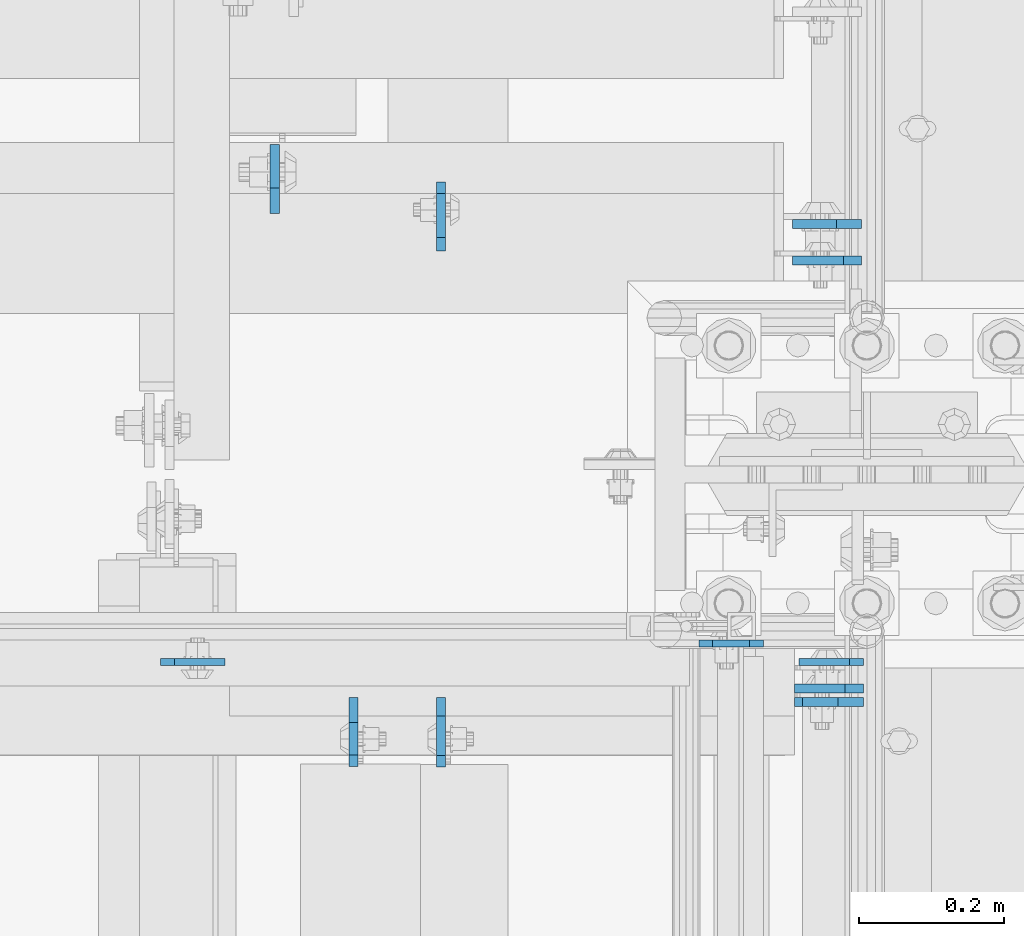
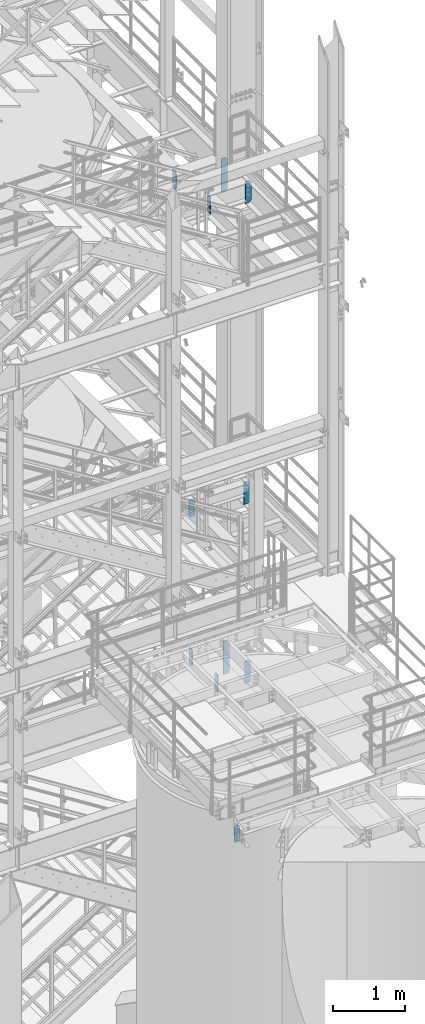
# One storey, part 1504 of 1876: 11 plates, 11 elements without a shape of their own.
"""IFC2X3 building model written with IfcOpenShell, lengths in millimetres."""

from ifc_helpers import new_model, si_unit, frame, origin_with_axes, place, context, subcontext, project, spatial, faceted_brep, material, type_object, element, aggregate, save


model = new_model("IFC2X3")

# Units and contexts
model_context = context("Model", 3, precision=1e-05, world=origin_with_axes())
body_context = subcontext(model_context, "Body", "Model", "MODEL_VIEW")
ifc_project = project(units=[si_unit("LENGTHUNIT", "METRE", prefix="MILLI"), si_unit("AREAUNIT", "SQUARE_METRE"), si_unit("VOLUMEUNIT", "CUBIC_METRE"), si_unit("MASSUNIT", "GRAM", prefix="KILO"), si_unit("TIMEUNIT", "SECOND"), si_unit("PLANEANGLEUNIT", "RADIAN"), si_unit("SOLIDANGLEUNIT", "STERADIAN"), si_unit("THERMODYNAMICTEMPERATUREUNIT", "DEGREE_CELSIUS"), si_unit("LUMINOUSINTENSITYUNIT", "LUMEN")], contexts=[model_context])

# Site, building, storey
site_placement = place(None, origin_with_axes())
site = spatial("IfcSite", under=ifc_project, at=site_placement, CompositionType="ELEMENT")
building_placement = place(site_placement, origin_with_axes())
building = spatial("IfcBuilding", under=site, at=building_placement, Name="Undefined", CompositionType="ELEMENT")
storey_placement = place(building_placement, origin_with_axes())
storey = spatial("IfcBuildingStorey", under=building, at=storey_placement, Name="Undefined", CompositionType="ELEMENT", Elevation=0.0)

# Assembly, plate
assembly_1_placement = place(storey_placement, origin_with_axes())
assembly_1 = element("IfcElementAssembly", 1, at=assembly_1_placement, inside=storey, Name="STRINGER", AssemblyPlace="NOTDEFINED", PredefinedType="RIGID_FRAME")
ifc_material = material(Name="STEEL/A36")
plate_type_1 = type_object("IfcPlateType", PredefinedType="NOTDEFINED")
plate_1_placement = place(assembly_1_placement, frame((7477.125, -4805.36300113047, 2044.9625725), z_axis=(-0.164335003932498, 0.0, 0.986404585594829), x_axis=(-0.986404585594829, 0.0, -0.164335003932498)))
plate_1 = element("IfcPlate", 2, at=plate_1_placement, type_object=plate_type_1, material=ifc_material, Name="PLATE", context=body_context, shape_type="Brep", body=[
    faceted_brep([(-3.13058175286437, -4.76249999999982, 18.7910065941451), (-40.8721457557156, -4.76249999999982, 245.331002683401), (-40.8721457557156, 4.76249999999982, 245.331002683401), (-3.13058175286437, 4.76249999999982, 18.7910065941451), (-25.9816576370417, -4.76249999999982, 270.29805264019), (-25.9816576370417, 4.76249999999982, 270.29805264019), (23.2336489088775, -4.76249999999982, 287.164746432251), (23.2336489088775, 4.76249999999982, 287.164746432251), (44.3853002035203, -4.76249999999982, 274.549783145812), (44.3853002035203, 4.76249999999982, 274.549783145812), (86.9947084938813, -4.76249999999982, 18.7910066490629), (86.9947084938813, 4.76249999999982, 18.7910066490629), (71.075290679928, -4.76249999999982, -2.95585778076202e-12), (71.075290679928, 4.76249999999982, -2.95585778076202e-12), (19.0499992370605, -4.76249999999982, 0.0), (19.0499992370605, 4.76249999999982, 0.0)], [[[0, 1, 2, 3]], [[1, 4, 5, 2]], [[4, 6, 7, 5]], [[6, 8, 9, 7]], [[8, 10, 11, 9]], [[10, 12, 13, 11]], [[12, 14, 15, 13]], [[14, 0, 3, 15]], [[5, 7, 9, 11, 13, 15, 3, 2]], [[14, 12, 10, 8, 6, 4, 1, 0]]]),
])
aggregate(assembly_1, [plate_1])

assembly_2_placement = place(storey_placement, origin_with_axes())
assembly_2 = element("IfcElementAssembly", 3, at=assembly_2_placement, inside=storey, Name="BEAM", AssemblyPlace="NOTDEFINED", PredefinedType="RIGID_FRAME")
plate_2_placement = place(assembly_2_placement, frame((7615.2375, -4830.76200121504, 7759.7), z_axis=(0.0, 0.0, 1.0), x_axis=(-1.0, 0.0, 0.0)))
plate_2 = element("IfcPlate", 4, at=plate_2_placement, type_object=plate_type_1, material=ifc_material, Name="PLATE", context=body_context, shape_type="Brep", body=[
    faceted_brep([(0.0, -4.76249999999982, 19.0499992370605), (0.0, -4.76250000000005, 360.362506866455), (0.0, 4.76250000000005, 360.362506866455), (0.0, 4.76249999999982, 19.0499992370605), (19.0499992370605, -4.76250000000005, 379.412506103516), (19.0499992370605, 4.76250000000005, 379.412506103516), (88.9000015258789, -4.76250000000005, 379.412506103516), (88.9000015258789, 4.76250000000005, 379.412506103516), (88.9000015258789, -4.76249999999982, 0.0), (88.9000015258789, 4.76249999999982, 0.0), (19.0499992370605, -4.76249999999982, 0.0), (19.0499992370605, 4.76249999999982, 0.0)], [[[0, 1, 2, 3]], [[1, 4, 5, 2]], [[4, 6, 7, 5]], [[6, 8, 9, 7]], [[8, 10, 11, 9]], [[10, 0, 3, 11]], [[5, 7, 9, 11, 3, 2]], [[10, 8, 6, 4, 1, 0]]]),
])
aggregate(assembly_2, [plate_2])

assembly_3_placement = place(storey_placement, origin_with_axes())
assembly_3 = element("IfcElementAssembly", 5, at=assembly_3_placement, inside=storey, Name="BEAM", AssemblyPlace="NOTDEFINED", PredefinedType="RIGID_FRAME")
plate_3_placement = place(assembly_3_placement, frame((6645.671875, -4830.76200121504, 7851.775), z_axis=(0.0, 0.0, 1.0), x_axis=(1.0, 0.0, 0.0)))
plate_3 = element("IfcPlate", 6, at=plate_3_placement, type_object=plate_type_1, material=ifc_material, Name="PLATE", context=body_context, shape_type="Brep", body=[
    faceted_brep([(0.0, -4.76249999999982, 19.0499992370605), (0.0, -4.76249999999982, 271.462512969971), (0.0, 4.76249999999982, 271.462512969971), (0.0, 4.76249999999982, 19.0499992370605), (19.0499992370605, -4.76249999999982, 290.512512207031), (19.0499992370605, 4.76249999999982, 290.512512207031), (88.9000015258789, -4.76249999999982, 290.512512207031), (88.9000015258789, 4.76249999999982, 290.512512207031), (88.9000015258789, -4.76249999999982, 0.0), (88.9000015258789, 4.76249999999982, 0.0), (19.0499992370605, -4.76249999999982, 0.0), (19.0499992370605, 4.76249999999982, 0.0)], [[[0, 1, 2, 3]], [[1, 4, 5, 2]], [[4, 6, 7, 5]], [[6, 8, 9, 7]], [[8, 10, 11, 9]], [[10, 0, 3, 11]], [[5, 7, 9, 11, 3, 2]], [[10, 8, 6, 4, 1, 0]]]),
])
aggregate(assembly_3, [plate_3])

assembly_4_placement = place(storey_placement, origin_with_axes())
assembly_4 = element("IfcElementAssembly", 7, at=assembly_4_placement, inside=storey, Name="BEAM", AssemblyPlace="NOTDEFINED", PredefinedType="RIGID_FRAME")
plate_type_2 = type_object("IfcPlateType", PredefinedType="NOTDEFINED")
plate_4_placement = place(assembly_4_placement, frame((6911.97499990463, -4879.578125, 13007.975), z_axis=(0.0, 0.0, 1.0), x_axis=(0.0, -1.0, 0.0)))
plate_4 = element("IfcPlate", 8, at=plate_4_placement, type_object=plate_type_2, material=ifc_material, Name="PLATE", context=body_context, shape_type="Brep", body=[
    faceted_brep([(0.0, -6.35000000000036, 255.587512969971), (34.9249992370605, -6.35000000000036, 290.512512207031), (34.9249992370605, 6.35000000000036, 290.512512207031), (0.0, 6.35000000000036, 255.587512969971), (0.0, -6.34999999999991, 34.9249992370605), (0.0, 6.34999999999991, 34.9249992370605), (34.9249992370605, -6.34999999999991, 0.0), (34.9249992370605, 6.34999999999991, 0.0), (95.25, -6.35000000000036, 0.0), (95.25, 6.35000000000036, 0.0), (95.25, -6.35000000000036, 277.812512016344), (79.3749874887271, -6.35000000000036, 290.512512207031), (79.3749874887271, 6.35000000000036, 290.512512207031), (95.25, 6.35000000000036, 277.812512016344)], [[[0, 1, 2, 3]], [[4, 0, 3, 5]], [[6, 4, 5, 7]], [[8, 6, 7, 9]], [[1, 0, 4, 6, 8, 10, 11]], [[2, 1, 11, 12]], [[9, 7, 5, 3, 2, 12, 13]], [[8, 9, 13, 10]], [[12, 11, 10, 13]]]),
])
aggregate(assembly_4, [plate_4])

assembly_5_placement = place(storey_placement, origin_with_axes())
assembly_5 = element("IfcElementAssembly", 9, at=assembly_5_placement, inside=storey, Name="BEAM", AssemblyPlace="NOTDEFINED", PredefinedType="RIGID_FRAME")
plate_5_placement = place(assembly_5_placement, frame((7615.2375, -4885.92812509537, 12915.9), z_axis=(0.0, 0.0, 1.0), x_axis=(-1.0, 0.0, 0.0)))
plate_5 = element("IfcPlate", 10, at=plate_5_placement, type_object=plate_type_2, material=ifc_material, Name="PLATE", context=body_context, shape_type="Brep", body=[
    faceted_brep([(0.0, -6.35000000000036, 344.487506866455), (34.9249992370605, -6.35000000000036, 379.412506103516), (34.9249992370605, 6.35000000000036, 379.412506103516), (0.0, 6.35000000000036, 344.487506866455), (0.0, -6.34999999999991, 34.9249992370605), (0.0, 6.34999999999991, 34.9249992370605), (34.9249992370605, -6.34999999999991, 0.0), (34.9249992370605, 6.34999999999991, 0.0), (95.25, -6.35000000000036, 0.0), (95.25, 6.35000000000036, 0.0), (95.25, -6.35000000000036, 368.300005476489), (84.136993261126, -6.35000000000036, 379.412506103516), (84.136993261126, 6.35000000000036, 379.412506103516), (95.25, 6.35000000000036, 368.300005476489)], [[[0, 1, 2, 3]], [[4, 0, 3, 5]], [[6, 4, 5, 7]], [[8, 6, 7, 9]], [[1, 0, 4, 6, 8, 10, 11]], [[2, 1, 11, 12]], [[9, 7, 5, 3, 2, 12, 13]], [[8, 9, 13, 10]], [[12, 11, 10, 13]]]),
])
aggregate(assembly_5, [plate_5])

assembly_6_placement = place(storey_placement, origin_with_axes())
assembly_6 = element("IfcElementAssembly", 11, at=assembly_6_placement, inside=storey, Name="BEAM", AssemblyPlace="NOTDEFINED", PredefinedType="RIGID_FRAME")
plate_6_placement = place(assembly_6_placement, frame((7612.85625, -4226.32187509537, 12714.2875), z_axis=(0.0, 0.0, 1.0), x_axis=(-1.0, 0.0, 0.0)))
plate_6 = element("IfcPlate", 12, at=plate_6_placement, type_object=plate_type_2, material=ifc_material, Name="PLATE", context=body_context, shape_type="Brep", body=[
    faceted_brep([(0.0, -6.34999999999991, 34.9249992370605), (0.0, -6.34999999999991, 534.987476348877), (0.0, 6.34999999999991, 534.987476348877), (0.0, 6.34999999999991, 34.9249992370605), (34.9249992370605, -6.34999999999991, 569.912475585938), (34.9249992370605, 6.34999999999991, 569.912475585938), (95.25, -6.35000000000036, 569.912475585938), (95.25, 6.35000000000036, 569.912475585938), (95.25, -6.35000000000036, 0.0), (95.25, 6.35000000000036, 0.0), (34.9249992370605, -6.34999999999991, 0.0), (34.9249992370605, 6.34999999999991, 0.0)], [[[0, 1, 2, 3]], [[1, 4, 5, 2]], [[4, 6, 7, 5]], [[6, 8, 9, 7]], [[8, 10, 11, 9]], [[10, 0, 3, 11]], [[5, 7, 9, 11, 3, 2]], [[10, 8, 6, 4, 1, 0]]]),
])
aggregate(assembly_6, [plate_6])

assembly_7_placement = place(storey_placement, origin_with_axes())
assembly_7 = element("IfcElementAssembly", 13, at=assembly_7_placement, inside=storey, Name="BEAM", AssemblyPlace="NOTDEFINED", PredefinedType="RIGID_FRAME")
plate_7_placement = place(assembly_7_placement, frame((6803.23124990463, -4212.034375, 12977.8125), z_axis=(0.0, 0.0, 1.0), x_axis=(0.0, 1.0, 0.0)))
plate_7 = element("IfcPlate", 14, at=plate_7_placement, type_object=plate_type_2, material=ifc_material, Name="PLATE", context=body_context, shape_type="Brep", body=[
    faceted_brep([(0.0, -6.34999999999991, 34.9249992370605), (0.0, -6.35000000000036, 280.987506866455), (0.0, 6.35000000000036, 280.987506866455), (0.0, 6.34999999999991, 34.9249992370605), (34.9249992370605, -6.35000000000036, 315.912506103516), (34.9249992370605, 6.35000000000036, 315.912506103516), (95.25, -6.35000000000036, 315.912506103516), (95.25, 6.35000000000036, 315.912506103516), (95.25, -6.35000000000036, 0.0), (95.25, 6.35000000000036, 0.0), (34.9249992370605, -6.34999999999991, 0.0), (34.9249992370605, 6.34999999999991, 0.0)], [[[0, 1, 2, 3]], [[1, 4, 5, 2]], [[4, 6, 7, 5]], [[6, 8, 9, 7]], [[8, 10, 11, 9]], [[10, 0, 3, 11]], [[5, 7, 9, 11, 3, 2]], [[10, 8, 6, 4, 1, 0]]]),
])
aggregate(assembly_7, [plate_7])

assembly_8_placement = place(storey_placement, origin_with_axes())
assembly_8 = element("IfcElementAssembly", 15, at=assembly_8_placement, inside=storey, Name="BEAM", AssemblyPlace="NOTDEFINED", PredefinedType="RIGID_FRAME")
plate_8_placement = place(assembly_8_placement, frame((7032.62499990463, -4879.975, 4829.175), z_axis=(0.0, 0.0, 1.0), x_axis=(0.0, -1.0, 0.0)))
plate_8 = element("IfcPlate", 16, at=plate_8_placement, type_object=plate_type_2, material=ifc_material, Name="PLATE", context=body_context, shape_type="Brep", body=[
    faceted_brep([(0.0, -6.35000000000036, 265.112512588501), (25.3999996185303, -6.35000000000036, 290.512512207031), (25.3999996185303, 6.35000000000036, 290.512512207031), (0.0, 6.35000000000036, 265.112512588501), (0.0, -6.35000000000036, 25.4000000000005), (0.0, 6.35000000000036, 25.4000000000005), (25.3999996185303, -6.34999999999991, 0.0), (25.3999996185303, 6.34999999999991, 0.0), (95.25, -6.35000000000036, 0.0), (95.25, 6.35000000000036, 0.0), (95.25, -6.35000000000036, 274.637511908913), (79.3749874887271, -6.35000000000036, 290.512512207031), (79.3749874887271, 6.35000000000036, 290.512512207031), (95.25, 6.35000000000036, 274.637511908913)], [[[0, 1, 2, 3]], [[4, 0, 3, 5]], [[6, 4, 5, 7]], [[8, 6, 7, 9]], [[1, 0, 4, 6, 8, 10, 11]], [[2, 1, 11, 12]], [[9, 7, 5, 3, 2, 12, 13]], [[8, 9, 13, 10]], [[12, 11, 10, 13]]]),
])
aggregate(assembly_8, [plate_8])

assembly_9_placement = place(storey_placement, origin_with_axes())
assembly_9 = element("IfcElementAssembly", 17, at=assembly_9_placement, inside=storey, Name="BEAM", AssemblyPlace="NOTDEFINED", PredefinedType="RIGID_FRAME")
plate_9_placement = place(assembly_9_placement, frame((7615.2375, -4867.27499990463, 4737.1), z_axis=(0.0, 0.0, 1.0), x_axis=(-1.0, 0.0, 0.0)))
plate_9 = element("IfcPlate", 18, at=plate_9_placement, type_object=plate_type_2, material=ifc_material, Name="PLATE", context=body_context, shape_type="Brep", body=[
    faceted_brep([(0.0, -6.35000000000036, 25.4000000000005), (0.0, -6.35000000000036, 354.012506484985), (0.0, 6.35000000000036, 354.012506484985), (0.0, 6.35000000000036, 25.4000000000005), (25.3999996185303, -6.35000000000036, 379.412506103516), (25.3999996185303, 6.35000000000036, 379.412506103516), (95.25, -6.35000000000036, 379.412506103516), (95.25, 6.35000000000036, 379.412506103516), (95.25, -6.35000000000036, 0.0), (95.25, 6.35000000000036, 0.0), (25.3999996185303, -6.34999999999991, 0.0), (25.3999996185303, 6.34999999999991, 0.0)], [[[0, 1, 2, 3]], [[1, 4, 5, 2]], [[4, 6, 7, 5]], [[6, 8, 9, 7]], [[8, 10, 11, 9]], [[10, 0, 3, 11]], [[5, 7, 9, 11, 3, 2]], [[10, 8, 6, 4, 1, 0]]]),
])
aggregate(assembly_9, [plate_9])

assembly_10_placement = place(storey_placement, origin_with_axes())
assembly_10 = element("IfcElementAssembly", 19, at=assembly_10_placement, inside=storey, Name="BEAM", AssemblyPlace="NOTDEFINED", PredefinedType="RIGID_FRAME")
plate_10_placement = place(assembly_10_placement, frame((7032.62499990463, -4264.025, 4829.175), z_axis=(0.0, 0.0, 1.0), x_axis=(0.0, 1.0, 0.0)))
plate_10 = element("IfcPlate", 20, at=plate_10_placement, type_object=plate_type_2, material=ifc_material, Name="PLATE", context=body_context, shape_type="Brep", body=[
    faceted_brep([(0.0, -6.35000000000036, 271.462512969971), (19.0499992370605, -6.35000000000036, 290.512512207031), (19.0499992370605, 6.35000000000036, 290.512512207031), (0.0, 6.35000000000036, 271.462512969971), (0.0, -6.35000000000196, 19.0499992370605), (0.0, 6.35000000000105, 19.0499992370605), (19.0499992370642, -6.35000000000105, 0.0), (19.0499992370633, 6.35000000000105, 0.0), (95.25, -6.35000000000036, 0.0), (95.25, 6.35000000000036, 0.0), (95.25, -6.35000000000036, 274.637511908913), (79.3749874887271, -6.35000000000036, 290.512512207031), (79.3749874887271, 6.35000000000036, 290.512512207031), (95.25, 6.35000000000036, 274.637511908913)], [[[0, 1, 2, 3]], [[4, 0, 3, 5]], [[6, 4, 5, 7]], [[8, 6, 7, 9]], [[1, 0, 4, 6, 8, 10, 11]], [[2, 1, 11, 12]], [[9, 7, 5, 3, 2, 12, 13]], [[8, 9, 13, 10]], [[12, 11, 10, 13]]]),
])
aggregate(assembly_10, [plate_10])

assembly_11_placement = place(storey_placement, origin_with_axes())
assembly_11 = element("IfcElementAssembly", 21, at=assembly_11_placement, inside=storey, Name="BEAM", AssemblyPlace="NOTDEFINED", PredefinedType="RIGID_FRAME")
plate_11_placement = place(assembly_11_placement, frame((7612.85625, -4276.72500009537, 4535.4875), z_axis=(0.0, 0.0, 1.0), x_axis=(-1.0, 0.0, 0.0)))
plate_11 = element("IfcPlate", 22, at=plate_11_placement, type_object=plate_type_2, material=ifc_material, Name="PLATE", context=body_context, shape_type="Brep", body=[
    faceted_brep([(0.0, -6.35000000000036, 25.4000000000005), (0.0, -6.35000000000036, 544.512475967407), (0.0, 6.35000000000036, 544.512475967407), (0.0, 6.35000000000036, 25.4000000000005), (25.3999996185303, -6.35000000000036, 569.912475585938), (25.3999996185303, 6.35000000000036, 569.912475585938), (95.25, -6.35000000000036, 569.912475585938), (95.25, 6.35000000000036, 569.912475585938), (95.25, -6.35000000000036, 0.0), (95.25, 6.35000000000036, 0.0), (25.3999996185303, -6.34999999999991, 0.0), (25.3999996185303, 6.34999999999991, 0.0)], [[[0, 1, 2, 3]], [[1, 4, 5, 2]], [[4, 6, 7, 5]], [[6, 8, 9, 7]], [[8, 10, 11, 9]], [[10, 0, 3, 11]], [[5, 7, 9, 11, 3, 2]], [[10, 8, 6, 4, 1, 0]]]),
])
aggregate(assembly_11, [plate_11])

save(model, "model.ifc")
